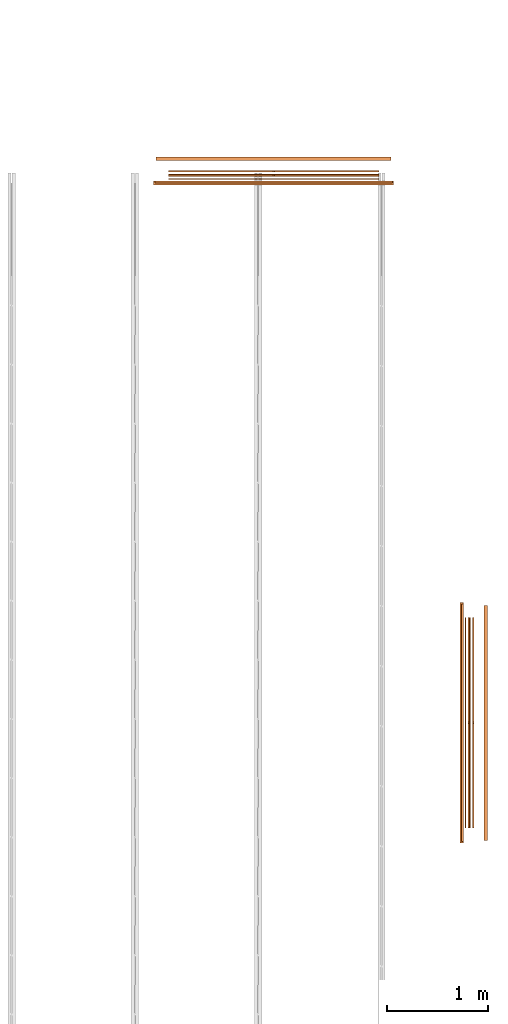
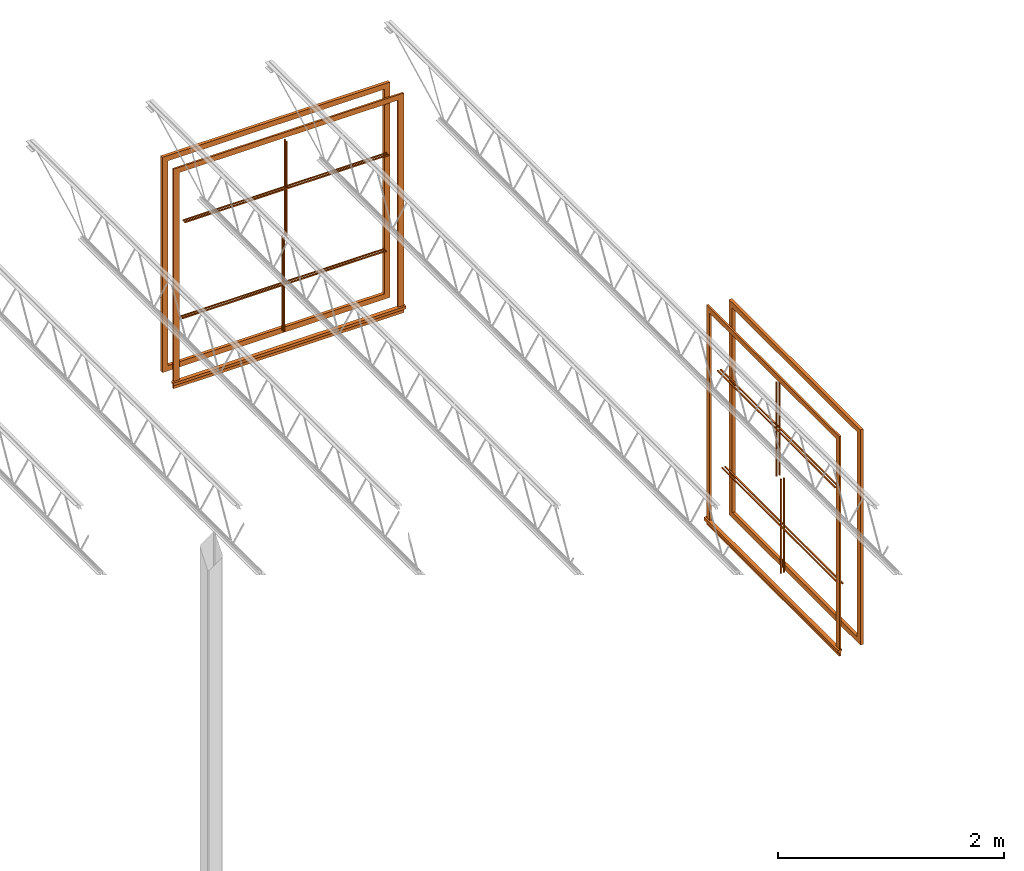
# One storey, part 31 of 31: 8 proxies.
"""IFC2X3 building model written with IfcOpenShell, lengths in feet."""

from ifc_helpers import new_model, entity, si_unit, converted_unit, derived_unit, direction, frame, origin, origin_2d_with_axis, place, context, subcontext, project, spatial, polyline, rectangle, outline, extrude, source, transform, mapped, material, material_list, type_object, type_shapes, element, save


model = new_model("IFC2X3")

# Units and contexts
model_context = context("Model", 3, precision=0.0001, world=origin(), true_north=direction((6.12303176911189e-17, 1.0)))
body_context = subcontext(model_context, "Body", "Model", "MODEL_VIEW")
ifc_project = project(units=[converted_unit("LENGTHUNIT", "FOOT", entity("IfcRatioMeasure", 0.3048), si_unit("LENGTHUNIT", "METRE"), dimensions=[1, 0, 0, 0, 0, 0, 0]), converted_unit("AREAUNIT", "SQUARE FOOT", entity("IfcRatioMeasure", 0.09290304), si_unit("AREAUNIT", "SQUARE_METRE"), dimensions=[2, 0, 0, 0, 0, 0, 0]), converted_unit("VOLUMEUNIT", "CUBIC FOOT", entity("IfcRatioMeasure", 0.028316846592), si_unit("VOLUMEUNIT", "CUBIC_METRE"), dimensions=[3, 0, 0, 0, 0, 0, 0]), converted_unit("PLANEANGLEUNIT", "DEGREE", entity("IfcRatioMeasure", 0.0174532925199433), si_unit("PLANEANGLEUNIT", "RADIAN"), dimensions=[0, 0, 0, 0, 0, 0, 0]), si_unit("MASSUNIT", "GRAM", prefix="KILO"), derived_unit("MASSDENSITYUNIT", [(si_unit("MASSUNIT", "GRAM", prefix="KILO"), 1), (si_unit("LENGTHUNIT", "METRE"), -3)]), si_unit("TIMEUNIT", "SECOND"), si_unit("FREQUENCYUNIT", "HERTZ"), si_unit("THERMODYNAMICTEMPERATUREUNIT", "DEGREE_CELSIUS"), derived_unit("THERMALTRANSMITTANCEUNIT", [(si_unit("MASSUNIT", "GRAM", prefix="KILO"), 1), (si_unit("THERMODYNAMICTEMPERATUREUNIT", "KELVIN"), -1), (si_unit("TIMEUNIT", "SECOND"), -3)]), derived_unit("VOLUMETRICFLOWRATEUNIT", [(si_unit("LENGTHUNIT", "METRE"), 3), (si_unit("TIMEUNIT", "SECOND"), -1)]), si_unit("ELECTRICCURRENTUNIT", "AMPERE"), si_unit("ELECTRICVOLTAGEUNIT", "VOLT"), si_unit("POWERUNIT", "WATT"), si_unit("FORCEUNIT", "NEWTON"), si_unit("ILLUMINANCEUNIT", "LUX"), si_unit("LUMINOUSFLUXUNIT", "LUMEN"), si_unit("LUMINOUSINTENSITYUNIT", "CANDELA"), derived_unit("USERDEFINED", [(si_unit("MASSUNIT", "GRAM", prefix="KILO"), -1), (si_unit("LENGTHUNIT", "METRE"), -2), (si_unit("TIMEUNIT", "SECOND"), 3), (si_unit("LUMINOUSFLUXUNIT", "LUMEN"), 1)]), derived_unit("LINEARVELOCITYUNIT", [(si_unit("LENGTHUNIT", "METRE"), 1), (si_unit("TIMEUNIT", "SECOND"), -1)]), si_unit("PRESSUREUNIT", "PASCAL"), derived_unit("USERDEFINED", [(si_unit("LENGTHUNIT", "METRE"), -2), (si_unit("MASSUNIT", "GRAM", prefix="KILO"), 1), (si_unit("TIMEUNIT", "SECOND"), -2)])], contexts=[model_context])

# Site, building, storey
site_placement = place(None, origin())
site = spatial("IfcSite", under=ifc_project, at=site_placement, CompositionType="ELEMENT")
building_placement = place(site_placement, origin())
building = spatial("IfcBuilding", under=site, at=building_placement, CompositionType="ELEMENT")
storey_placement = place(building_placement, frame((0.0, 0.0, 13.3333333333323)))
storey = spatial("IfcBuildingStorey", under=building, at=storey_placement, Name="Level 2", CompositionType="ELEMENT", Elevation=13.3333333333323)

# Proxies
ifc_material_1 = material(Name="Wood - Stained")
ifc_material_2 = material(Name="Clad - White 61141")
ifc_material_list_1 = material_list([ifc_material_1, ifc_material_2])
ifc_material_list_2 = material_list([ifc_material_1, ifc_material_2])
building_element_proxy_type_1 = type_object("IfcBuildingElementProxyType", Name="Muntin Pattern_2x2:Muntin Pattern_2x2", PredefinedType="NOTDEFINED", material=ifc_material_list_2)
shared_shape_1 = source(origin(), body_context, "Body", "SweptSolid", [
    extrude(outline(polyline([(-1.67187499999989, 0.0208333333334139), (-1.67187499999989, -0.0208333333332504), (-0.0208333333333748, -0.0208333333332504), (-0.0208333333333748, -3.4166666666668), (0.0208333333332895, -3.4166666666668), (0.0208333333332895, -0.0208333333332789), (1.67187500000003, -0.0208333333332789), (1.67187500000003, 0.0208333333333925), (0.0208333333333002, 0.0208333333333925), (0.0208333333333002, 3.41666666666652), (-0.0208333333333677, 3.41666666666652), (-0.0208333333333677, 0.0208333333334139), (-1.67187499999989, 0.0208333333334139)])), frame((54.5264992691726, 36.1641066247015, 21.7447916666666), z_axis=(-1.0, 0.0, 0.0), x_axis=(0.0, 0.0, -1.0)), (0.0, 0.0, -1.0), 0.0416666666666572),
    extrude(outline(polyline([(-1.6718749999996, 0.020833333333421), (-1.6718749999996, -0.0208333333332362), (-0.0208333333334672, -0.0208333333332362), (-0.0208333333334672, -3.41666666666681), (0.02083333333319, -3.41666666666681), (0.02083333333319, -0.0208333333332646), (1.67187500000009, -0.0208333333332646), (1.67187500000009, 0.0208333333333854), (0.0208333333332114, 0.0208333333333854), (0.0208333333332114, 3.41666666666651), (-0.0208333333334529, 3.41666666666651), (-0.0208333333334529, 0.020833333333421), (-1.6718749999996, 0.020833333333421)])), frame((54.4223326025059, 36.1641066247015, 21.7447916666663), z_axis=(-1.0, 0.0, 0.0), x_axis=(0.0, 0.0, -1.0)), (0.0, 0.0, -1.0), 0.0416666666666501),
])
type_shapes(building_element_proxy_type_1, [shared_shape_1])
proxy_1_placement = place(building_placement, origin())
element("IfcBuildingElementProxy", 1, at=proxy_1_placement, inside=storey, type_object=building_element_proxy_type_1, material=ifc_material_list_1, ObjectType="Muntin Pattern_2x2 : Muntin Pattern_2x2:Muntin Pattern_2x2", context=body_context, shape_type="MappedRepresentation", body=[
    mapped(shared_shape_1, transform((0.0, 0.0, 0.0), scale=1.0)),
])
ifc_material_list_3 = material_list([ifc_material_1, ifc_material_2])
ifc_material_list_4 = material_list([ifc_material_1, ifc_material_2])
building_element_proxy_type_2 = type_object("IfcBuildingElementProxyType", Name="Muntin Pattern_2x2:Muntin Pattern_2x2", PredefinedType="NOTDEFINED", material=ifc_material_list_4)
shared_shape_2 = source(origin(), body_context, "Body", "SweptSolid", [
    extrude(outline(polyline([(-1.67187499999989, 0.0208333333334139), (-1.67187499999989, -0.0208333333332504), (-0.0208333333333748, -0.0208333333332504), (-0.0208333333333748, -3.4166666666668), (0.0208333333332895, -3.4166666666668), (0.0208333333332895, -0.0208333333332789), (1.67187500000003, -0.0208333333332789), (1.67187500000003, 0.0208333333333925), (0.0208333333333002, 0.0208333333333925), (0.0208333333333002, 3.41666666666652), (-0.0208333333333677, 3.41666666666652), (-0.0208333333333677, 0.0208333333334139), (-1.67187499999989, 0.0208333333334139)])), frame((54.672332602506, 36.1641066247015, 18.2552083333333), z_axis=(-1.0, 0.0, 0.0), x_axis=(0.0, 0.0, -1.0)), (0.0, 0.0, -1.0), 0.0416666666666572),
    extrude(outline(polyline([(-1.6718749999996, 0.020833333333421), (-1.6718749999996, -0.0208333333332362), (-0.0208333333334672, -0.0208333333332362), (-0.0208333333334672, -3.41666666666681), (0.02083333333319, -3.41666666666681), (0.02083333333319, -0.0208333333332646), (1.67187500000009, -0.0208333333332646), (1.67187500000009, 0.0208333333333854), (0.0208333333332149, 0.0208333333333854), (0.0208333333332149, 3.41666666666651), (-0.0208333333334458, 3.41666666666651), (-0.0208333333334458, 0.020833333333421), (-1.6718749999996, 0.020833333333421)])), frame((54.5681659358393, 36.1641066247015, 18.2552083333331), z_axis=(-1.0, 0.0, 0.0), x_axis=(0.0, 0.0, -1.0)), (0.0, 0.0, -1.0), 0.0416666666666501),
])
type_shapes(building_element_proxy_type_2, [shared_shape_2])
proxy_2_placement = place(building_placement, origin())
element("IfcBuildingElementProxy", 2, at=proxy_2_placement, inside=storey, type_object=building_element_proxy_type_2, material=ifc_material_list_3, ObjectType="Muntin Pattern_2x2 : Muntin Pattern_2x2:Muntin Pattern_2x2", context=body_context, shape_type="MappedRepresentation", body=[
    mapped(shared_shape_2, transform((0.0, 0.0, 0.0), scale=1.0)),
])
building_element_proxy_type_3 = type_object("IfcBuildingElementProxyType", Name="Trim-Window-Exterior-Flat:with Sill", PredefinedType="NOTDEFINED", material=ifc_material_2)
shared_shape_3 = source(origin(), body_context, "Body", "SweptSolid", [
    extrude(outline(polyline([(-3.71354166666666, -3.85416666666666), (3.80729166666667, -3.85416666666666), (3.80729166666667, 3.85416666666666), (-3.71354166666666, 3.85416666666666), (-3.71354166666666, 3.66666666666667), (3.61979166666666, 3.66666666666667), (3.61979166666666, -3.66666666666666), (-3.71354166666666, -3.66666666666666), (-3.71354166666666, -3.85416666666666)])), frame((54.3181659358393, 36.1641066247017, 20.046875), z_axis=(1.0, 0.0, 0.0), x_axis=(0.0, 0.0, 1.0)), (0.0, 0.0, 1.0), 0.0625),
    extrude(outline(polyline([(0.0, -0.0524593146393144), (0.0624999999999503, -0.0524593146393144), (0.0624999999999503, 0.0436428358983321), (0.0, 0.0517073520273605), (-0.0624999999999289, 0.0517073520273605), (-0.0624999999999289, -0.0210694553372015), (0.0, -0.0210694553372015), (0.0, -0.0524593146393144)])), frame((54.3181659358393, 32.2682732913683, 16.2816259813059), z_axis=(0.0, 1.0, 0.0), x_axis=(-1.0, 0.0, 0.0)), (0.0, 0.0, 1.0), 7.79166666666668),
    extrude(rectangle(XDim=0.0625, YDim=7.70833333333333, at=origin_2d_with_axis()), frame((54.3494159358393, 36.1641066247017, 16.0730565259687)), (0.0, 0.0, 1.0), 0.187500000000004),
])
type_shapes(building_element_proxy_type_3, [shared_shape_3])
proxy_3_placement = place(building_placement, origin())
element("IfcBuildingElementProxy", 3, at=proxy_3_placement, inside=storey, type_object=building_element_proxy_type_3, material=ifc_material_2, ObjectType="with Sill : Trim-Window-Exterior-Flat:with Sill", context=body_context, shape_type="MappedRepresentation", body=[
    mapped(shared_shape_3, transform((0.0, 0.0, 0.0), scale=1.0)),
])
building_element_proxy_type_4 = type_object("IfcBuildingElementProxyType", Name="Trim-Window-Interior-Flat:Picture Frame", PredefinedType="NOTDEFINED", material=ifc_material_1)
shared_shape_4 = source(origin(), body_context, "Body", "SweptSolid", [
    extrude(outline(polyline([(-3.81249999999998, -3.81249999999999), (3.81249999999998, -3.81249999999999), (3.81249999999998, 3.81249999999999), (-3.81249999999998, 3.81249999999999), (-3.81249999999998, -3.81249999999999)]), holes=[polyline([(3.62499999999997, 3.62500000000001), (3.62499999999997, -3.62499999999999), (-3.62499999999998, -3.62499999999999), (-3.62499999999998, 3.62500000000001), (3.62499999999997, 3.62500000000001)])]), frame((55.047332602506, 36.1641066247017, 20.0), z_axis=(1.0, 0.0, 0.0), x_axis=(0.0, 0.0, -1.0)), (0.0, 0.0, 1.0), 0.104166666666664),
])
type_shapes(building_element_proxy_type_4, [shared_shape_4])
proxy_4_placement = place(building_placement, origin())
element("IfcBuildingElementProxy", 4, at=proxy_4_placement, inside=storey, type_object=building_element_proxy_type_4, material=ifc_material_1, ObjectType="Picture Frame : Trim-Window-Interior-Flat:Picture Frame", context=body_context, shape_type="MappedRepresentation", body=[
    mapped(shared_shape_4, transform((0.0, 0.0, 0.0), scale=1.0)),
])
ifc_material_list_5 = material_list([ifc_material_1, ifc_material_2])
ifc_material_list_6 = material_list([ifc_material_1, ifc_material_2])
building_element_proxy_type_5 = type_object("IfcBuildingElementProxyType", Name="Muntin Pattern_2x2:Muntin Pattern_2x2", PredefinedType="NOTDEFINED", material=ifc_material_list_6)
shared_shape_5 = source(origin(), body_context, "Body", "SweptSolid", [
    extrude(outline(polyline([(-1.67187499999989, 0.0208333333334139), (-1.67187499999989, -0.0208333333332504), (-0.0208333333333748, -0.0208333333332504), (-0.0208333333333748, -3.4166666666668), (0.0208333333332895, -3.4166666666668), (0.0208333333332895, -0.0208333333332789), (1.67187500000003, -0.0208333333332789), (1.67187500000003, 0.0208333333333925), (0.0208333333333002, 0.0208333333333925), (0.0208333333333002, 3.41666666666652), (-0.0208333333333677, 3.41666666666652), (-0.0208333333333677, 0.0208333333334139), (-1.67187499999989, 0.0208333333334139)])), frame((48.2139992691728, 53.8932732913684, 21.7447916666666), z_axis=(0.0, -1.0, 0.0), x_axis=(0.0, 0.0, -1.0)), (0.0, 0.0, -1.0), 0.0416666666666572),
    extrude(outline(polyline([(-1.6718749999996, 0.020833333333421), (-1.6718749999996, -0.0208333333332362), (-0.0208333333334672, -0.0208333333332362), (-0.0208333333334672, -3.41666666666681), (0.02083333333319, -3.41666666666681), (0.02083333333319, -0.0208333333332646), (1.67187500000009, -0.0208333333332646), (1.67187500000009, 0.0208333333333854), (0.0208333333332114, 0.0208333333333854), (0.0208333333332114, 3.41666666666651), (-0.0208333333334529, 3.41666666666651), (-0.0208333333334529, 0.020833333333421), (-1.6718749999996, 0.020833333333421)])), frame((48.2139992691728, 53.7891066247017, 21.7447916666663), z_axis=(0.0, -1.0, 0.0), x_axis=(0.0, 0.0, -1.0)), (0.0, 0.0, -1.0), 0.0416666666666501),
])
type_shapes(building_element_proxy_type_5, [shared_shape_5])
proxy_5_placement = place(building_placement, origin())
element("IfcBuildingElementProxy", 5, at=proxy_5_placement, inside=storey, type_object=building_element_proxy_type_5, material=ifc_material_list_5, ObjectType="Muntin Pattern_2x2 : Muntin Pattern_2x2:Muntin Pattern_2x2", context=body_context, shape_type="MappedRepresentation", body=[
    mapped(shared_shape_5, transform((0.0, 0.0, 0.0), scale=1.0)),
])
ifc_material_list_7 = material_list([ifc_material_1, ifc_material_2])
ifc_material_list_8 = material_list([ifc_material_1, ifc_material_2])
building_element_proxy_type_6 = type_object("IfcBuildingElementProxyType", Name="Muntin Pattern_2x2:Muntin Pattern_2x2", PredefinedType="NOTDEFINED", material=ifc_material_list_8)
shared_shape_6 = source(origin(), body_context, "Body", "SweptSolid", [
    extrude(outline(polyline([(-1.67187499999989, 0.0208333333334139), (-1.67187499999989, -0.0208333333332504), (-0.0208333333333748, -0.0208333333332504), (-0.0208333333333748, -3.4166666666668), (0.0208333333332895, -3.4166666666668), (0.0208333333332895, -0.0208333333332789), (1.67187500000003, -0.0208333333332789), (1.67187500000003, 0.0208333333333925), (0.0208333333333002, 0.0208333333333925), (0.0208333333333002, 3.41666666666652), (-0.0208333333333677, 3.41666666666652), (-0.0208333333333677, 0.0208333333334139), (-1.67187499999989, 0.0208333333334139)])), frame((48.2139992691728, 54.0391066247017, 18.2552083333333), z_axis=(0.0, -1.0, 0.0), x_axis=(0.0, 0.0, -1.0)), (0.0, 0.0, -1.0), 0.0416666666666572),
    extrude(outline(polyline([(-1.6718749999996, 0.020833333333421), (-1.6718749999996, -0.0208333333332362), (-0.0208333333334672, -0.0208333333332362), (-0.0208333333334672, -3.41666666666681), (0.02083333333319, -3.41666666666681), (0.02083333333319, -0.0208333333332646), (1.67187500000009, -0.0208333333332646), (1.67187500000009, 0.0208333333333854), (0.0208333333332149, 0.0208333333333854), (0.0208333333332149, 3.41666666666651), (-0.0208333333334458, 3.41666666666651), (-0.0208333333334458, 0.020833333333421), (-1.6718749999996, 0.020833333333421)])), frame((48.2139992691728, 53.934939958035, 18.2552083333331), z_axis=(0.0, -1.0, 0.0), x_axis=(0.0, 0.0, -1.0)), (0.0, 0.0, -1.0), 0.0416666666666501),
])
type_shapes(building_element_proxy_type_6, [shared_shape_6])
proxy_6_placement = place(building_placement, origin())
element("IfcBuildingElementProxy", 6, at=proxy_6_placement, inside=storey, type_object=building_element_proxy_type_6, material=ifc_material_list_7, ObjectType="Muntin Pattern_2x2 : Muntin Pattern_2x2:Muntin Pattern_2x2", context=body_context, shape_type="MappedRepresentation", body=[
    mapped(shared_shape_6, transform((0.0, 0.0, 0.0), scale=1.0)),
])
building_element_proxy_type_7 = type_object("IfcBuildingElementProxyType", Name="Trim-Window-Exterior-Flat:with Sill", PredefinedType="NOTDEFINED", material=ifc_material_2)
shared_shape_7 = source(origin(), body_context, "Body", "SweptSolid", [
    extrude(outline(polyline([(-3.71354166666666, -3.85416666666667), (3.80729166666667, -3.85416666666667), (3.80729166666667, 3.85416666666665), (-3.71354166666666, 3.85416666666665), (-3.71354166666666, 3.66666666666666), (3.61979166666666, 3.66666666666666), (3.61979166666666, -3.66666666666666), (-3.71354166666666, -3.66666666666666), (-3.71354166666666, -3.85416666666667)])), frame((48.2139992691726, 53.684939958035, 20.046875), z_axis=(0.0, 1.0, 0.0), x_axis=(0.0, 0.0, 1.0)), (0.0, 0.0, 1.0), 0.0625),
    extrude(outline(polyline([(-0.052459314639318, 0.0), (-0.052459314639318, -0.0624999999999432), (0.0436428358983285, -0.0624999999999432), (0.051707352027357, 0.0), (0.051707352027357, 0.0624999999999361), (-0.0210694553372051, 0.0624999999999361), (-0.0210694553372051, 0.0), (-0.052459314639318, 0.0)])), frame((44.3181659358393, 53.6849399580351, 16.2816259813059), z_axis=(-1.0, 0.0, 0.0), x_axis=(0.0, 0.0, 1.0)), (0.0, 0.0, -1.0), 7.79166666666668),
    extrude(rectangle(XDim=0.0625, YDim=7.70833333333333, at=origin_2d_with_axis()), frame((48.2139992691726, 53.716189958035, 16.0730565259687), z_axis=(0.0, 0.0, 1.0), x_axis=(0.0, 1.0, 0.0)), (0.0, 0.0, 1.0), 0.187500000000004),
])
type_shapes(building_element_proxy_type_7, [shared_shape_7])
proxy_7_placement = place(building_placement, origin())
element("IfcBuildingElementProxy", 7, at=proxy_7_placement, inside=storey, type_object=building_element_proxy_type_7, material=ifc_material_2, ObjectType="with Sill : Trim-Window-Exterior-Flat:with Sill", context=body_context, shape_type="MappedRepresentation", body=[
    mapped(shared_shape_7, transform((0.0, 0.0, 0.0), scale=1.0)),
])
building_element_proxy_type_8 = type_object("IfcBuildingElementProxyType", Name="Trim-Window-Interior-Flat:Picture Frame", PredefinedType="NOTDEFINED", material=ifc_material_1)
shared_shape_8 = source(origin(), body_context, "Body", "SweptSolid", [
    extrude(outline(polyline([(-3.81249999999998, -3.81249999999999), (3.81249999999998, -3.81249999999999), (3.81249999999998, 3.81249999999999), (-3.81249999999998, 3.81249999999999), (-3.81249999999998, -3.81249999999999)]), holes=[polyline([(3.62499999999997, 3.62500000000001), (3.62499999999997, -3.62499999999999), (-3.62499999999998, -3.62499999999999), (-3.62499999999998, 3.62500000000001), (3.62499999999997, 3.62500000000001)])]), frame((48.2139992691727, 54.4141066247017, 20.0), z_axis=(0.0, 1.0, 0.0), x_axis=(0.0, 0.0, -1.0)), (0.0, 0.0, 1.0), 0.104166666666664),
])
type_shapes(building_element_proxy_type_8, [shared_shape_8])
proxy_8_placement = place(building_placement, origin())
element("IfcBuildingElementProxy", 8, at=proxy_8_placement, inside=storey, type_object=building_element_proxy_type_8, material=ifc_material_1, ObjectType="Picture Frame : Trim-Window-Interior-Flat:Picture Frame", context=body_context, shape_type="MappedRepresentation", body=[
    mapped(shared_shape_8, transform((0.0, 0.0, 0.0), scale=1.0)),
])

save(model, "model.ifc")
